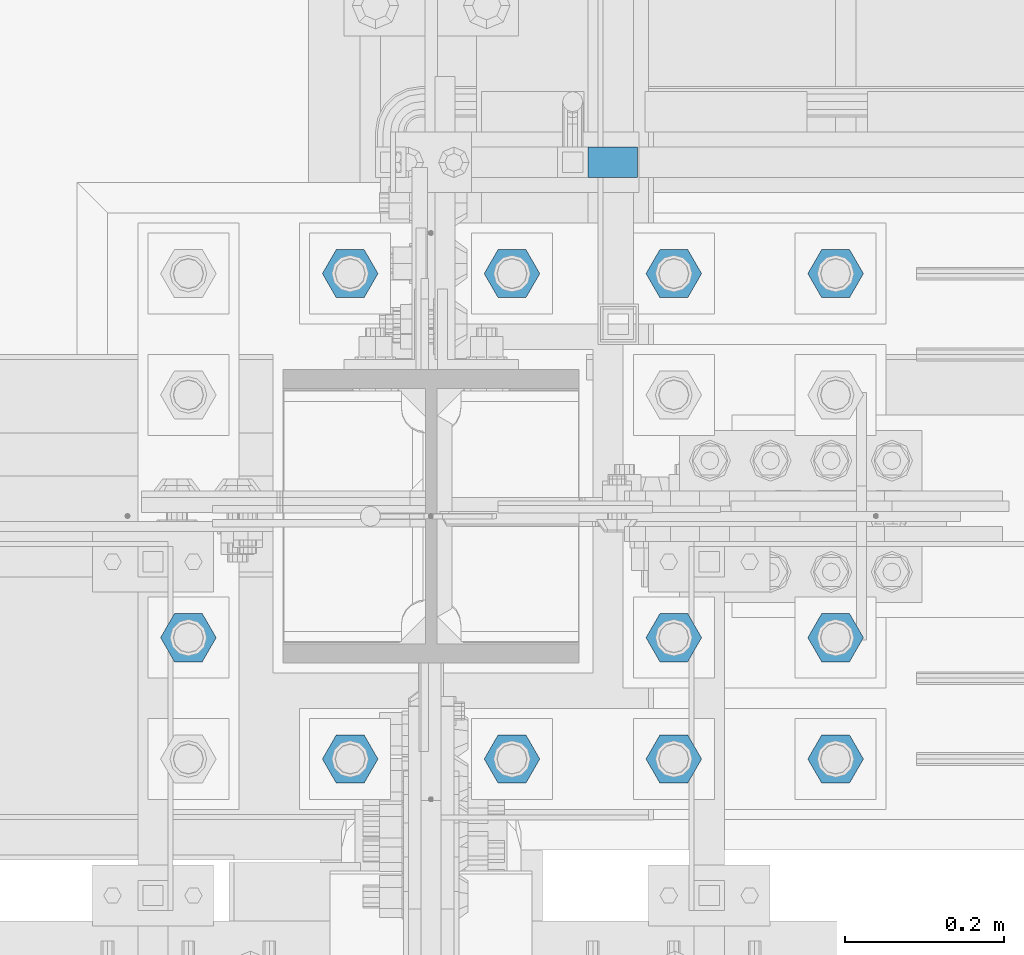
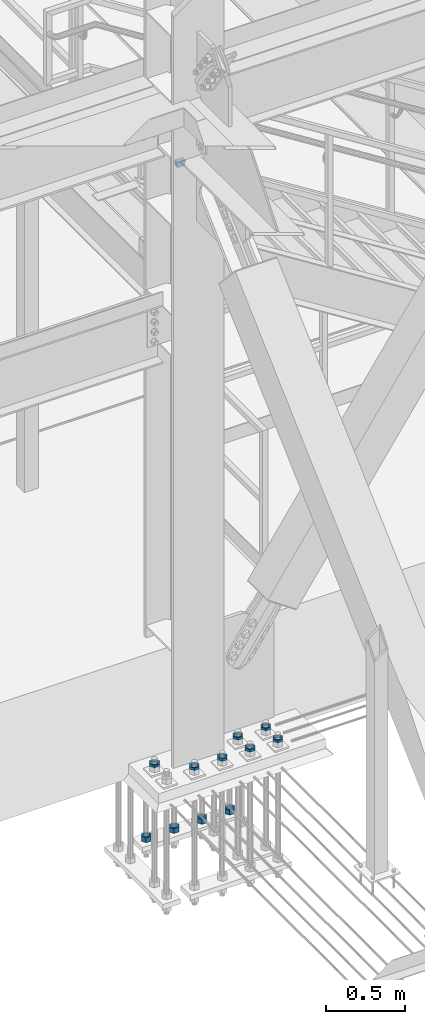
# One storey, part 2825 of 3843: 12 beams, 2 elements without a shape of their own.
"""IFC2X3 building model written with IfcOpenShell, lengths in millimetres."""

from ifc_helpers import new_model, si_unit, frame, origin_with_axes, place, context, subcontext, project, spatial, faceted_brep, material, type_object, element, aggregate, save


model = new_model("IFC2X3")

# Units and contexts
model_context = context("Model", 3, precision=1e-05, world=origin_with_axes())
body_context = subcontext(model_context, "Body", "Model", "MODEL_VIEW")
ifc_project = project(units=[si_unit("LENGTHUNIT", "METRE", prefix="MILLI"), si_unit("AREAUNIT", "SQUARE_METRE"), si_unit("VOLUMEUNIT", "CUBIC_METRE"), si_unit("MASSUNIT", "GRAM", prefix="KILO"), si_unit("TIMEUNIT", "SECOND"), si_unit("PLANEANGLEUNIT", "RADIAN"), si_unit("SOLIDANGLEUNIT", "STERADIAN"), si_unit("THERMODYNAMICTEMPERATUREUNIT", "DEGREE_CELSIUS"), si_unit("LUMINOUSINTENSITYUNIT", "LUMEN")], contexts=[model_context])

# Site, building, storey
site_placement = place(None, origin_with_axes())
site = spatial("IfcSite", under=ifc_project, at=site_placement, CompositionType="ELEMENT")
building_placement = place(site_placement, origin_with_axes())
building = spatial("IfcBuilding", under=site, at=building_placement, Name="Undefined", CompositionType="ELEMENT")
storey_placement = place(building_placement, origin_with_axes())
storey = spatial("IfcBuildingStorey", under=building, at=storey_placement, Name="Undefined", CompositionType="ELEMENT", Elevation=0.0)

# Assembly, beam
assembly_1_placement = place(storey_placement, origin_with_axes())
assembly_1 = element("IfcElementAssembly", 1, at=assembly_1_placement, inside=storey, Name="RAIL", AssemblyPlace="NOTDEFINED", PredefinedType="RIGID_FRAME")
ifc_material_1 = material()
beam_type_1 = type_object("IfcBeamType", Name="HSS1-1/2X1-1/2X1/4", PredefinedType="NOTDEFINED")
beam_1_placement = place(assembly_1_placement, frame((56184.7999995789, 26060.40000005, 33832.8000003305), z_axis=(0.0, 0.0, 1.0), x_axis=(-1.0, 0.0, 0.0)))
beam_1 = element("IfcBeam", 2, at=beam_1_placement, type_object=beam_type_1, material=ifc_material_1, Name="RAIL", ObjectType="HSS1-1/2X1-1/2X1/4", context=body_context, shape_type="Brep", body=[
    faceted_brep([(57.1499996326966, -19.0500003825, 19.0499992351833), (57.1499996707935, -19.0499992350015, -19.0499992348123), (57.1499996707935, 19.0499992350015, -19.0499992348123), (57.1499996326966, 19.0499992350015, 19.0499992351833), (57.1499996390485, -12.6999993300014, 12.699999330187), (57.1499996390485, 12.6999993300014, 12.699999330187), (57.1499996644488, 12.6999993300014, -12.6999993298159), (57.1499996644488, -12.6999993300014, -12.6999993298159), (-5.50550323203788, 19.0499992350015, 19.0499992349796), (-5.50550323203788, -19.0499992350015, 19.0499992349796), (5.50550336230663, -19.0499992350015, -19.0499992349796), (5.50550336230663, 19.0499992350015, -19.0499992349796), (-3.67033542007266, 12.6999993300014, 12.6999993299905), (-3.67033542007266, -12.6999993300014, 12.6999993299905), (3.67033555034141, -12.6999993300014, -12.6999993299905), (3.67033555034141, 12.6999993300014, -12.6999993299905)], [[[0, 1, 2, 3], [4, 5, 6, 7]], [[8, 9, 0, 3]], [[10, 11, 2, 1]], [[9, 10, 1, 0]], [[11, 8, 3, 2]], [[10, 9, 8, 11], [12, 13, 14, 15]], [[14, 13, 4, 7]], [[15, 14, 7, 6]], [[12, 15, 6, 5]], [[13, 12, 5, 4]]]),
])
aggregate(assembly_1, [beam_1])

# Assembly, beams
assembly_2_placement = place(storey_placement, origin_with_axes())
assembly_2 = element("IfcElementAssembly", 3, at=assembly_2_placement, inside=storey, Name="TEMPLATE", AssemblyPlace="NOTDEFINED", PredefinedType="RIGID_FRAME")
ifc_material_2 = material(Name="STEEL/A572-50")
beam_type_2 = type_object("IfcBeamType", Name="1-1/2_HEAVY_HEX_NUT", PredefinedType="NOTDEFINED")
beam_2_placement = place(assembly_2_placement, frame((55829.2, 25920.7, 28841.7000015259), z_axis=(0.0, -1.0, 0.0), x_axis=(0.0, 0.0, -1.0)))
beam_2 = element("IfcBeam", 4, at=beam_2_placement, type_object=beam_type_2, material=ifc_material_2, Name="NUT", ObjectType="1-1/2_HEAVY_HEX_NUT", context=body_context, shape_type="Brep", body=[
    faceted_brep([(0.0, -34.9199981689453, 0.0), (0.0, -17.4599990844727, -30.25), (38.0999999999985, -17.4599990844727, -30.25), (38.0999999999985, -34.9199981689453, 0.0), (0.0, 17.4599990844727, -30.25), (38.0999999999985, 17.4599990844727, -30.25), (0.0, 34.9199981689453, 0.0), (38.0999999999985, 34.9199981689453, 0.0), (0.0, 17.4599990844727, 30.25), (38.0999999999985, 17.4599990844727, 30.25), (0.0, -17.4599990844727, 30.25), (38.0999999999985, -17.4599990844727, 30.25), (0.0, 0.0, 20.6399993896484), (0.0, 8.9553601105581, 18.5959968835959), (38.0999999999985, 8.9553601105581, 18.5959968835959), (38.0999999999985, 0.0, 20.6399993896484), (0.0, 16.1370013209525, 12.8688291298167), (38.0999999999985, 16.1370013209525, 12.8688291298167), (0.0, 20.1225115123816, 4.59283194104501), (38.0999999999985, 20.1225115123816, 4.59283194104501), (0.0, 20.1225115123816, -4.59283194104501), (38.0999999999985, 20.1225115123816, -4.59283194104501), (0.0, 16.1370013209525, -12.8688291298167), (38.0999999999985, 16.1370013209525, -12.8688291298167), (0.0, 8.9553601105581, -18.5959968835959), (38.0999999999985, 8.9553601105581, -18.5959968835959), (0.0, 0.0, -20.6399993896484), (38.0999999999985, 0.0, -20.6399993896484), (0.0, -8.9553601105581, -18.5959968835959), (38.0999999999985, -8.9553601105581, -18.5959968835959), (0.0, -16.1370013209525, -12.8688291298167), (38.0999999999985, -16.1370013209525, -12.8688291298167), (0.0, -20.1225115123816, -4.59283194104501), (38.0999999999985, -20.1225115123816, -4.59283194104501), (0.0, -20.1225115123816, 4.59283194104501), (38.0999999999985, -20.1225115123816, 4.59283194104501), (0.0, -16.1370013209525, 12.8688291298167), (38.0999999999985, -16.1370013209525, 12.8688291298167), (0.0, -8.9553601105581, 18.5959968835959), (38.0999999999985, -8.9553601105581, 18.5959968835959)], [[[0, 1, 2, 3]], [[1, 4, 5, 2]], [[4, 6, 7, 5]], [[6, 8, 9, 7]], [[8, 10, 11, 9]], [[10, 0, 3, 11]], [[12, 13, 14, 15]], [[13, 16, 17, 14]], [[16, 18, 19, 17]], [[18, 20, 21, 19]], [[20, 22, 23, 21]], [[22, 24, 25, 23]], [[24, 26, 27, 25]], [[26, 28, 29, 27]], [[28, 30, 31, 29]], [[30, 32, 33, 31]], [[32, 34, 35, 33]], [[34, 36, 37, 35]], [[36, 38, 39, 37]], [[38, 12, 15, 39]], [[5, 7, 9, 11, 3, 2], [17, 19, 21, 23, 25, 27, 29, 31, 33, 35, 37, 39, 15, 14]], [[10, 8, 6, 4, 1, 0], [38, 36, 34, 32, 30, 28, 26, 24, 22, 20, 18, 16, 13, 12]]]),
])
beam_3_placement = place(assembly_2_placement, frame((56032.4, 25920.7, 28841.7000015259), z_axis=(0.0, -1.0, 0.0), x_axis=(0.0, 0.0, -1.0)))
beam_3 = element("IfcBeam", 5, at=beam_3_placement, type_object=beam_type_2, material=ifc_material_2, Name="NUT", ObjectType="1-1/2_HEAVY_HEX_NUT", context=body_context, shape_type="Brep", body=[
    faceted_brep([(0.0, -34.9199981689453, 0.0), (0.0, -17.4599990844727, -30.25), (38.0999999999985, -17.4599990844727, -30.25), (38.0999999999985, -34.9199981689453, 0.0), (0.0, 17.4599990844727, -30.25), (38.0999999999985, 17.4599990844727, -30.25), (0.0, 34.9199981689453, 0.0), (38.0999999999985, 34.9199981689453, 0.0), (0.0, 17.4599990844727, 30.25), (38.0999999999985, 17.4599990844727, 30.25), (0.0, -17.4599990844727, 30.25), (38.0999999999985, -17.4599990844727, 30.25), (0.0, 0.0, 20.6399993896484), (0.0, 8.9553601105581, 18.5959968835959), (38.0999999999985, 8.9553601105581, 18.5959968835959), (38.0999999999985, 0.0, 20.6399993896484), (0.0, 16.1370013209525, 12.8688291298167), (38.0999999999985, 16.1370013209525, 12.8688291298167), (0.0, 20.1225115123816, 4.59283194104501), (38.0999999999985, 20.1225115123816, 4.59283194104501), (0.0, 20.1225115123816, -4.59283194104501), (38.0999999999985, 20.1225115123816, -4.59283194104501), (0.0, 16.1370013209525, -12.8688291298167), (38.0999999999985, 16.1370013209525, -12.8688291298167), (0.0, 8.9553601105581, -18.5959968835959), (38.0999999999985, 8.9553601105581, -18.5959968835959), (0.0, 0.0, -20.6399993896484), (38.0999999999985, 0.0, -20.6399993896484), (0.0, -8.9553601105581, -18.5959968835959), (38.0999999999985, -8.9553601105581, -18.5959968835959), (0.0, -16.1370013209525, -12.8688291298167), (38.0999999999985, -16.1370013209525, -12.8688291298167), (0.0, -20.1225115123816, -4.59283194104501), (38.0999999999985, -20.1225115123816, -4.59283194104501), (0.0, -20.1225115123816, 4.59283194104501), (38.0999999999985, -20.1225115123816, 4.59283194104501), (0.0, -16.1370013209525, 12.8688291298167), (38.0999999999985, -16.1370013209525, 12.8688291298167), (0.0, -8.9553601105581, 18.5959968835959), (38.0999999999985, -8.9553601105581, 18.5959968835959)], [[[0, 1, 2, 3]], [[1, 4, 5, 2]], [[4, 6, 7, 5]], [[6, 8, 9, 7]], [[8, 10, 11, 9]], [[10, 0, 3, 11]], [[12, 13, 14, 15]], [[13, 16, 17, 14]], [[16, 18, 19, 17]], [[18, 20, 21, 19]], [[20, 22, 23, 21]], [[22, 24, 25, 23]], [[24, 26, 27, 25]], [[26, 28, 29, 27]], [[28, 30, 31, 29]], [[30, 32, 33, 31]], [[32, 34, 35, 33]], [[34, 36, 37, 35]], [[36, 38, 39, 37]], [[38, 12, 15, 39]], [[5, 7, 9, 11, 3, 2], [17, 19, 21, 23, 25, 27, 29, 31, 33, 35, 37, 39, 15, 14]], [[10, 8, 6, 4, 1, 0], [38, 36, 34, 32, 30, 28, 26, 24, 22, 20, 18, 16, 13, 12]]]),
])
beam_4_placement = place(assembly_2_placement, frame((56235.6, 25920.7, 28841.7000015259), z_axis=(0.0, 1.0, 0.0), x_axis=(0.0, 0.0, -1.0)))
beam_4 = element("IfcBeam", 6, at=beam_4_placement, type_object=beam_type_2, material=ifc_material_2, Name="NUT", ObjectType="1-1/2_HEAVY_HEX_NUT", context=body_context, shape_type="Brep", body=[
    faceted_brep([(0.0, -34.9199981689453, 0.0), (0.0, -17.4599990844727, -30.25), (38.0999999999985, -17.4599990844727, -30.25), (38.0999999999985, -34.9199981689453, 0.0), (0.0, 17.4599990844727, -30.25), (38.0999999999985, 17.4599990844727, -30.25), (0.0, 34.9199981689453, 0.0), (38.0999999999985, 34.9199981689453, 0.0), (0.0, 17.4599990844727, 30.25), (38.0999999999985, 17.4599990844727, 30.25), (0.0, -17.4599990844727, 30.25), (38.0999999999985, -17.4599990844727, 30.25), (0.0, 0.0, 20.6399993896484), (0.0, 8.9553601105581, 18.5959968835959), (38.0999999999985, 8.9553601105581, 18.5959968835959), (38.0999999999985, 0.0, 20.6399993896484), (0.0, 16.1370013209525, 12.8688291298167), (38.0999999999985, 16.1370013209525, 12.8688291298167), (0.0, 20.1225115123816, 4.59283194104501), (38.0999999999985, 20.1225115123816, 4.59283194104501), (0.0, 20.1225115123816, -4.59283194104501), (38.0999999999985, 20.1225115123816, -4.59283194104501), (0.0, 16.1370013209525, -12.8688291298167), (38.0999999999985, 16.1370013209525, -12.8688291298167), (0.0, 8.9553601105581, -18.5959968835959), (38.0999999999985, 8.9553601105581, -18.5959968835959), (0.0, 0.0, -20.6399993896484), (38.0999999999985, 0.0, -20.6399993896484), (0.0, -8.9553601105581, -18.5959968835959), (38.0999999999985, -8.9553601105581, -18.5959968835959), (0.0, -16.1370013209525, -12.8688291298167), (38.0999999999985, -16.1370013209525, -12.8688291298167), (0.0, -20.1225115123816, -4.59283194104501), (38.0999999999985, -20.1225115123816, -4.59283194104501), (0.0, -20.1225115123816, 4.59283194104501), (38.0999999999985, -20.1225115123816, 4.59283194104501), (0.0, -16.1370013209525, 12.8688291298167), (38.0999999999985, -16.1370013209525, 12.8688291298167), (0.0, -8.9553601105581, 18.5959968835959), (38.0999999999985, -8.9553601105581, 18.5959968835959)], [[[0, 1, 2, 3]], [[1, 4, 5, 2]], [[4, 6, 7, 5]], [[6, 8, 9, 7]], [[8, 10, 11, 9]], [[10, 0, 3, 11]], [[12, 13, 14, 15]], [[13, 16, 17, 14]], [[16, 18, 19, 17]], [[18, 20, 21, 19]], [[20, 22, 23, 21]], [[22, 24, 25, 23]], [[24, 26, 27, 25]], [[26, 28, 29, 27]], [[28, 30, 31, 29]], [[30, 32, 33, 31]], [[32, 34, 35, 33]], [[34, 36, 37, 35]], [[36, 38, 39, 37]], [[38, 12, 15, 39]], [[5, 7, 9, 11, 3, 2], [17, 19, 21, 23, 25, 27, 29, 31, 33, 35, 37, 39, 15, 14]], [[10, 8, 6, 4, 1, 0], [38, 36, 34, 32, 30, 28, 26, 24, 22, 20, 18, 16, 13, 12]]]),
])
beam_5_placement = place(assembly_2_placement, frame((56438.8, 25920.7, 28841.7000015259), z_axis=(0.0, 1.0, 0.0), x_axis=(0.0, 0.0, -1.0)))
beam_5 = element("IfcBeam", 7, at=beam_5_placement, type_object=beam_type_2, material=ifc_material_2, Name="NUT", ObjectType="1-1/2_HEAVY_HEX_NUT", context=body_context, shape_type="Brep", body=[
    faceted_brep([(0.0, -34.9199981689453, 0.0), (0.0, -17.4599990844727, -30.25), (38.0999999999985, -17.4599990844727, -30.25), (38.0999999999985, -34.9199981689453, 0.0), (0.0, 17.4599990844727, -30.25), (38.0999999999985, 17.4599990844727, -30.25), (0.0, 34.9199981689453, 0.0), (38.0999999999985, 34.9199981689453, 0.0), (0.0, 17.4599990844727, 30.25), (38.0999999999985, 17.4599990844727, 30.25), (0.0, -17.4599990844727, 30.25), (38.0999999999985, -17.4599990844727, 30.25), (0.0, 0.0, 20.6399993896484), (0.0, 8.9553601105581, 18.5959968835959), (38.0999999999985, 8.9553601105581, 18.5959968835959), (38.0999999999985, 0.0, 20.6399993896484), (0.0, 16.1370013209525, 12.8688291298167), (38.0999999999985, 16.1370013209525, 12.8688291298167), (0.0, 20.1225115123816, 4.59283194104501), (38.0999999999985, 20.1225115123816, 4.59283194104501), (0.0, 20.1225115123816, -4.59283194104501), (38.0999999999985, 20.1225115123816, -4.59283194104501), (0.0, 16.1370013209525, -12.8688291298167), (38.0999999999985, 16.1370013209525, -12.8688291298167), (0.0, 8.9553601105581, -18.5959968835959), (38.0999999999985, 8.9553601105581, -18.5959968835959), (0.0, 0.0, -20.6399993896484), (38.0999999999985, 0.0, -20.6399993896484), (0.0, -8.9553601105581, -18.5959968835959), (38.0999999999985, -8.9553601105581, -18.5959968835959), (0.0, -16.1370013209525, -12.8688291298167), (38.0999999999985, -16.1370013209525, -12.8688291298167), (0.0, -20.1225115123816, -4.59283194104501), (38.0999999999985, -20.1225115123816, -4.59283194104501), (0.0, -20.1225115123816, 4.59283194104501), (38.0999999999985, -20.1225115123816, 4.59283194104501), (0.0, -16.1370013209525, 12.8688291298167), (38.0999999999985, -16.1370013209525, 12.8688291298167), (0.0, -8.9553601105581, 18.5959968835959), (38.0999999999985, -8.9553601105581, 18.5959968835959)], [[[0, 1, 2, 3]], [[1, 4, 5, 2]], [[4, 6, 7, 5]], [[6, 8, 9, 7]], [[8, 10, 11, 9]], [[10, 0, 3, 11]], [[12, 13, 14, 15]], [[13, 16, 17, 14]], [[16, 18, 19, 17]], [[18, 20, 21, 19]], [[20, 22, 23, 21]], [[22, 24, 25, 23]], [[24, 26, 27, 25]], [[26, 28, 29, 27]], [[28, 30, 31, 29]], [[30, 32, 33, 31]], [[32, 34, 35, 33]], [[34, 36, 37, 35]], [[36, 38, 39, 37]], [[38, 12, 15, 39]], [[5, 7, 9, 11, 3, 2], [17, 19, 21, 23, 25, 27, 29, 31, 33, 35, 37, 39, 15, 14]], [[10, 8, 6, 4, 1, 0], [38, 36, 34, 32, 30, 28, 26, 24, 22, 20, 18, 16, 13, 12]]]),
])
beam_type_3 = type_object("IfcBeamType", Name="1-1/2_HALF_NUT", PredefinedType="NOTDEFINED")
beam_6_placement = place(assembly_2_placement, frame((55829.2, 25311.1, 29749.75), z_axis=(0.0, -1.0, 0.0), x_axis=(0.0, 0.0, -1.0)))
beam_6 = element("IfcBeam", 8, at=beam_6_placement, type_object=beam_type_3, material=ifc_material_2, Name="NUT", ObjectType="1-1/2_HALF_NUT", context=body_context, shape_type="Brep", body=[
    faceted_brep([(0.0, -34.9199981689453, 0.0), (0.0, -17.4599990844727, -30.25), (19.0500000000029, -17.4599990844727, -30.25), (19.0500000000029, -34.9199981689453, 0.0), (0.0, 17.4599990844727, -30.25), (19.0500000000029, 17.4599990844727, -30.25), (0.0, 34.9199981689453, 0.0), (19.0500000000029, 34.9199981689453, 0.0), (0.0, 17.4599990844727, 30.25), (19.0500000000029, 17.4599990844727, 30.25), (0.0, -17.4599990844727, 30.25), (19.0500000000029, -17.4599990844727, 30.25), (0.0, 0.0, 20.6399993896484), (0.0, 8.9553601105581, 18.5959968835959), (19.0500000000029, 8.95536011056538, 18.5959968835959), (19.0500000000029, 0.0, 20.6399993896484), (0.0, 16.1370013209525, 12.8688291298167), (19.0500000000029, 16.1370013209489, 12.8688291298167), (0.0, 20.1225115123816, 4.59283194104501), (19.0500000000029, 20.1225115123852, 4.59283194104501), (0.0, 20.1225115123816, -4.59283194104501), (19.0500000000029, 20.1225115123852, -4.59283194104501), (0.0, 16.1370013209525, -12.8688291298167), (19.0500000000029, 16.1370013209489, -12.8688291298167), (0.0, 8.9553601105581, -18.5959968835959), (19.0500000000029, 8.95536011056538, -18.5959968835959), (0.0, 0.0, -20.6399993896484), (19.0500000000029, 0.0, -20.6399993896484), (0.0, -8.9553601105581, -18.5959968835959), (19.0500000000029, -8.95536011056538, -18.5959968835959), (0.0, -16.1370013209525, -12.8688291298167), (19.0500000000029, -16.1370013209489, -12.8688291298167), (0.0, -20.1225115123816, -4.59283194104501), (19.0500000000029, -20.1225115123852, -4.59283194104501), (0.0, -20.1225115123816, 4.59283194104501), (19.0500000000029, -20.1225115123852, 4.59283194104501), (0.0, -16.1370013209525, 12.8688291298167), (19.0500000000029, -16.1370013209489, 12.8688291298167), (0.0, -8.9553601105581, 18.5959968835959), (19.0500000000029, -8.95536011056538, 18.5959968835959)], [[[0, 1, 2, 3]], [[1, 4, 5, 2]], [[4, 6, 7, 5]], [[6, 8, 9, 7]], [[8, 10, 11, 9]], [[10, 0, 3, 11]], [[12, 13, 14, 15]], [[13, 16, 17, 14]], [[16, 18, 19, 17]], [[18, 20, 21, 19]], [[20, 22, 23, 21]], [[22, 24, 25, 23]], [[24, 26, 27, 25]], [[26, 28, 29, 27]], [[28, 30, 31, 29]], [[30, 32, 33, 31]], [[32, 34, 35, 33]], [[34, 36, 37, 35]], [[36, 38, 39, 37]], [[38, 12, 15, 39]], [[5, 7, 9, 11, 3, 2], [17, 19, 21, 23, 25, 27, 29, 31, 33, 35, 37, 39, 15, 14]], [[10, 8, 6, 4, 1, 0], [38, 36, 34, 32, 30, 28, 26, 24, 22, 20, 18, 16, 13, 12]]]),
])
beam_7_placement = place(assembly_2_placement, frame((56032.4, 25311.1, 29749.75), z_axis=(0.0, -1.0, 0.0), x_axis=(0.0, 0.0, -1.0)))
beam_7 = element("IfcBeam", 9, at=beam_7_placement, type_object=beam_type_3, material=ifc_material_2, Name="NUT", ObjectType="1-1/2_HALF_NUT", context=body_context, shape_type="Brep", body=[
    faceted_brep([(0.0, -34.9199981689453, 0.0), (0.0, -17.4599990844727, -30.25), (19.0500000000029, -17.4599990844727, -30.25), (19.0500000000029, -34.9199981689453, 0.0), (0.0, 17.4599990844727, -30.25), (19.0500000000029, 17.4599990844727, -30.25), (0.0, 34.9199981689453, 0.0), (19.0500000000029, 34.9199981689453, 0.0), (0.0, 17.4599990844727, 30.25), (19.0500000000029, 17.4599990844727, 30.25), (0.0, -17.4599990844727, 30.25), (19.0500000000029, -17.4599990844727, 30.25), (0.0, 0.0, 20.6399993896484), (0.0, 8.9553601105581, 18.5959968835959), (19.0500000000029, 8.95536011056538, 18.5959968835959), (19.0500000000029, 0.0, 20.6399993896484), (0.0, 16.1370013209525, 12.8688291298167), (19.0500000000029, 16.1370013209489, 12.8688291298167), (0.0, 20.1225115123816, 4.59283194104501), (19.0500000000029, 20.1225115123852, 4.59283194104501), (0.0, 20.1225115123816, -4.59283194104501), (19.0500000000029, 20.1225115123852, -4.59283194104501), (0.0, 16.1370013209525, -12.8688291298167), (19.0500000000029, 16.1370013209489, -12.8688291298167), (0.0, 8.9553601105581, -18.5959968835959), (19.0500000000029, 8.95536011056538, -18.5959968835959), (0.0, 0.0, -20.6399993896484), (19.0500000000029, 0.0, -20.6399993896484), (0.0, -8.9553601105581, -18.5959968835959), (19.0500000000029, -8.95536011056538, -18.5959968835959), (0.0, -16.1370013209525, -12.8688291298167), (19.0500000000029, -16.1370013209489, -12.8688291298167), (0.0, -20.1225115123816, -4.59283194104501), (19.0500000000029, -20.1225115123852, -4.59283194104501), (0.0, -20.1225115123816, 4.59283194104501), (19.0500000000029, -20.1225115123852, 4.59283194104501), (0.0, -16.1370013209525, 12.8688291298167), (19.0500000000029, -16.1370013209489, 12.8688291298167), (0.0, -8.9553601105581, 18.5959968835959), (19.0500000000029, -8.95536011056538, 18.5959968835959)], [[[0, 1, 2, 3]], [[1, 4, 5, 2]], [[4, 6, 7, 5]], [[6, 8, 9, 7]], [[8, 10, 11, 9]], [[10, 0, 3, 11]], [[12, 13, 14, 15]], [[13, 16, 17, 14]], [[16, 18, 19, 17]], [[18, 20, 21, 19]], [[20, 22, 23, 21]], [[22, 24, 25, 23]], [[24, 26, 27, 25]], [[26, 28, 29, 27]], [[28, 30, 31, 29]], [[30, 32, 33, 31]], [[32, 34, 35, 33]], [[34, 36, 37, 35]], [[36, 38, 39, 37]], [[38, 12, 15, 39]], [[5, 7, 9, 11, 3, 2], [17, 19, 21, 23, 25, 27, 29, 31, 33, 35, 37, 39, 15, 14]], [[10, 8, 6, 4, 1, 0], [38, 36, 34, 32, 30, 28, 26, 24, 22, 20, 18, 16, 13, 12]]]),
])
beam_8_placement = place(assembly_2_placement, frame((56235.6, 25311.1, 29749.75), z_axis=(0.0, 1.0, 0.0), x_axis=(0.0, 0.0, -1.0)))
beam_8 = element("IfcBeam", 10, at=beam_8_placement, type_object=beam_type_3, material=ifc_material_2, Name="NUT", ObjectType="1-1/2_HALF_NUT", context=body_context, shape_type="Brep", body=[
    faceted_brep([(0.0, -34.9199981689453, 0.0), (0.0, -17.4599990844727, -30.25), (19.0500000000029, -17.4599990844727, -30.25), (19.0500000000029, -34.9199981689453, 0.0), (0.0, 17.4599990844727, -30.25), (19.0500000000029, 17.4599990844727, -30.25), (0.0, 34.9199981689453, 0.0), (19.0500000000029, 34.9199981689453, 0.0), (0.0, 17.4599990844727, 30.25), (19.0500000000029, 17.4599990844727, 30.25), (0.0, -17.4599990844727, 30.25), (19.0500000000029, -17.4599990844727, 30.25), (0.0, 0.0, 20.6399993896484), (0.0, 8.9553601105581, 18.5959968835959), (19.0500000000029, 8.95536011056538, 18.5959968835959), (19.0500000000029, 0.0, 20.6399993896484), (0.0, 16.1370013209525, 12.8688291298167), (19.0500000000029, 16.1370013209489, 12.8688291298167), (0.0, 20.1225115123816, 4.59283194104501), (19.0500000000029, 20.1225115123852, 4.59283194104501), (0.0, 20.1225115123816, -4.59283194104501), (19.0500000000029, 20.1225115123852, -4.59283194104501), (0.0, 16.1370013209525, -12.8688291298167), (19.0500000000029, 16.1370013209489, -12.8688291298167), (0.0, 8.9553601105581, -18.5959968835959), (19.0500000000029, 8.95536011056538, -18.5959968835959), (0.0, 0.0, -20.6399993896484), (19.0500000000029, 0.0, -20.6399993896484), (0.0, -8.9553601105581, -18.5959968835959), (19.0500000000029, -8.95536011056538, -18.5959968835959), (0.0, -16.1370013209525, -12.8688291298167), (19.0500000000029, -16.1370013209489, -12.8688291298167), (0.0, -20.1225115123816, -4.59283194104501), (19.0500000000029, -20.1225115123852, -4.59283194104501), (0.0, -20.1225115123816, 4.59283194104501), (19.0500000000029, -20.1225115123852, 4.59283194104501), (0.0, -16.1370013209525, 12.8688291298167), (19.0500000000029, -16.1370013209489, 12.8688291298167), (0.0, -8.9553601105581, 18.5959968835959), (19.0500000000029, -8.95536011056538, 18.5959968835959)], [[[0, 1, 2, 3]], [[1, 4, 5, 2]], [[4, 6, 7, 5]], [[6, 8, 9, 7]], [[8, 10, 11, 9]], [[10, 0, 3, 11]], [[12, 13, 14, 15]], [[13, 16, 17, 14]], [[16, 18, 19, 17]], [[18, 20, 21, 19]], [[20, 22, 23, 21]], [[22, 24, 25, 23]], [[24, 26, 27, 25]], [[26, 28, 29, 27]], [[28, 30, 31, 29]], [[30, 32, 33, 31]], [[32, 34, 35, 33]], [[34, 36, 37, 35]], [[36, 38, 39, 37]], [[38, 12, 15, 39]], [[5, 7, 9, 11, 3, 2], [17, 19, 21, 23, 25, 27, 29, 31, 33, 35, 37, 39, 15, 14]], [[10, 8, 6, 4, 1, 0], [38, 36, 34, 32, 30, 28, 26, 24, 22, 20, 18, 16, 13, 12]]]),
])
beam_9_placement = place(assembly_2_placement, frame((56438.8, 25311.1, 29749.75), z_axis=(0.0, 1.0, 0.0), x_axis=(0.0, 0.0, -1.0)))
beam_9 = element("IfcBeam", 11, at=beam_9_placement, type_object=beam_type_3, material=ifc_material_2, Name="NUT", ObjectType="1-1/2_HALF_NUT", context=body_context, shape_type="Brep", body=[
    faceted_brep([(0.0, -34.9199981689453, 0.0), (0.0, -17.4599990844727, -30.25), (19.0500000000029, -17.4599990844727, -30.25), (19.0500000000029, -34.9199981689453, 0.0), (0.0, 17.4599990844727, -30.25), (19.0500000000029, 17.4599990844727, -30.25), (0.0, 34.9199981689453, 0.0), (19.0500000000029, 34.9199981689453, 0.0), (0.0, 17.4599990844727, 30.25), (19.0500000000029, 17.4599990844727, 30.25), (0.0, -17.4599990844727, 30.25), (19.0500000000029, -17.4599990844727, 30.25), (0.0, 0.0, 20.6399993896484), (0.0, 8.9553601105581, 18.5959968835959), (19.0500000000029, 8.95536011056538, 18.5959968835959), (19.0500000000029, 0.0, 20.6399993896484), (0.0, 16.1370013209525, 12.8688291298167), (19.0500000000029, 16.1370013209489, 12.8688291298167), (0.0, 20.1225115123816, 4.59283194104501), (19.0500000000029, 20.1225115123852, 4.59283194104501), (0.0, 20.1225115123816, -4.59283194104501), (19.0500000000029, 20.1225115123852, -4.59283194104501), (0.0, 16.1370013209525, -12.8688291298167), (19.0500000000029, 16.1370013209489, -12.8688291298167), (0.0, 8.9553601105581, -18.5959968835959), (19.0500000000029, 8.95536011056538, -18.5959968835959), (0.0, 0.0, -20.6399993896484), (19.0500000000029, 0.0, -20.6399993896484), (0.0, -8.9553601105581, -18.5959968835959), (19.0500000000029, -8.95536011056538, -18.5959968835959), (0.0, -16.1370013209525, -12.8688291298167), (19.0500000000029, -16.1370013209489, -12.8688291298167), (0.0, -20.1225115123816, -4.59283194104501), (19.0500000000029, -20.1225115123852, -4.59283194104501), (0.0, -20.1225115123816, 4.59283194104501), (19.0500000000029, -20.1225115123852, 4.59283194104501), (0.0, -16.1370013209525, 12.8688291298167), (19.0500000000029, -16.1370013209489, 12.8688291298167), (0.0, -8.9553601105581, 18.5959968835959), (19.0500000000029, -8.95536011056538, 18.5959968835959)], [[[0, 1, 2, 3]], [[1, 4, 5, 2]], [[4, 6, 7, 5]], [[6, 8, 9, 7]], [[8, 10, 11, 9]], [[10, 0, 3, 11]], [[12, 13, 14, 15]], [[13, 16, 17, 14]], [[16, 18, 19, 17]], [[18, 20, 21, 19]], [[20, 22, 23, 21]], [[22, 24, 25, 23]], [[24, 26, 27, 25]], [[26, 28, 29, 27]], [[28, 30, 31, 29]], [[30, 32, 33, 31]], [[32, 34, 35, 33]], [[34, 36, 37, 35]], [[36, 38, 39, 37]], [[38, 12, 15, 39]], [[5, 7, 9, 11, 3, 2], [17, 19, 21, 23, 25, 27, 29, 31, 33, 35, 37, 39, 15, 14]], [[10, 8, 6, 4, 1, 0], [38, 36, 34, 32, 30, 28, 26, 24, 22, 20, 18, 16, 13, 12]]]),
])
beam_10_placement = place(assembly_2_placement, frame((55626.0, 25463.5, 29749.75), z_axis=(0.0, -1.0, 0.0), x_axis=(0.0, 0.0, -1.0)))
beam_10 = element("IfcBeam", 12, at=beam_10_placement, type_object=beam_type_3, material=ifc_material_2, Name="NUT", ObjectType="1-1/2_HALF_NUT", context=body_context, shape_type="Brep", body=[
    faceted_brep([(0.0, -34.9199981689453, 0.0), (0.0, -17.4599990844727, -30.25), (19.0500000000029, -17.4599990844727, -30.25), (19.0500000000029, -34.9199981689453, 0.0), (0.0, 17.4599990844727, -30.25), (19.0500000000029, 17.4599990844727, -30.25), (0.0, 34.9199981689453, 0.0), (19.0500000000029, 34.9199981689453, 0.0), (0.0, 17.4599990844727, 30.25), (19.0500000000029, 17.4599990844727, 30.25), (0.0, -17.4599990844727, 30.25), (19.0500000000029, -17.4599990844727, 30.25), (0.0, 0.0, 20.6399993896484), (0.0, 8.9553601105581, 18.5959968835959), (19.0500000000029, 8.95536011056538, 18.5959968835959), (19.0500000000029, 0.0, 20.6399993896484), (0.0, 16.1370013209525, 12.8688291298167), (19.0500000000029, 16.1370013209489, 12.8688291298167), (0.0, 20.1225115123816, 4.59283194104501), (19.0500000000029, 20.1225115123852, 4.59283194104501), (0.0, 20.1225115123816, -4.59283194104501), (19.0500000000029, 20.1225115123852, -4.59283194104501), (0.0, 16.1370013209525, -12.8688291298167), (19.0500000000029, 16.1370013209489, -12.8688291298167), (0.0, 8.9553601105581, -18.5959968835959), (19.0500000000029, 8.95536011056538, -18.5959968835959), (0.0, 0.0, -20.6399993896484), (19.0500000000029, 0.0, -20.6399993896484), (0.0, -8.9553601105581, -18.5959968835959), (19.0500000000029, -8.95536011056538, -18.5959968835959), (0.0, -16.1370013209525, -12.8688291298167), (19.0500000000029, -16.1370013209489, -12.8688291298167), (0.0, -20.1225115123816, -4.59283194104501), (19.0500000000029, -20.1225115123852, -4.59283194104501), (0.0, -20.1225115123816, 4.59283194104501), (19.0500000000029, -20.1225115123852, 4.59283194104501), (0.0, -16.1370013209525, 12.8688291298167), (19.0500000000029, -16.1370013209489, 12.8688291298167), (0.0, -8.9553601105581, 18.5959968835959), (19.0500000000029, -8.95536011056538, 18.5959968835959)], [[[0, 1, 2, 3]], [[1, 4, 5, 2]], [[4, 6, 7, 5]], [[6, 8, 9, 7]], [[8, 10, 11, 9]], [[10, 0, 3, 11]], [[12, 13, 14, 15]], [[13, 16, 17, 14]], [[16, 18, 19, 17]], [[18, 20, 21, 19]], [[20, 22, 23, 21]], [[22, 24, 25, 23]], [[24, 26, 27, 25]], [[26, 28, 29, 27]], [[28, 30, 31, 29]], [[30, 32, 33, 31]], [[32, 34, 35, 33]], [[34, 36, 37, 35]], [[36, 38, 39, 37]], [[38, 12, 15, 39]], [[5, 7, 9, 11, 3, 2], [17, 19, 21, 23, 25, 27, 29, 31, 33, 35, 37, 39, 15, 14]], [[10, 8, 6, 4, 1, 0], [38, 36, 34, 32, 30, 28, 26, 24, 22, 20, 18, 16, 13, 12]]]),
])
beam_11_placement = place(assembly_2_placement, frame((56235.6, 25463.5, 29749.75), z_axis=(0.0, 1.0, 0.0), x_axis=(0.0, 0.0, -1.0)))
beam_11 = element("IfcBeam", 13, at=beam_11_placement, type_object=beam_type_3, material=ifc_material_2, Name="NUT", ObjectType="1-1/2_HALF_NUT", context=body_context, shape_type="Brep", body=[
    faceted_brep([(0.0, -34.9199981689453, 0.0), (0.0, -17.4599990844727, -30.25), (19.0500000000029, -17.4599990844727, -30.25), (19.0500000000029, -34.9199981689453, 0.0), (0.0, 17.4599990844727, -30.25), (19.0500000000029, 17.4599990844727, -30.25), (0.0, 34.9199981689453, 0.0), (19.0500000000029, 34.9199981689453, 0.0), (0.0, 17.4599990844727, 30.25), (19.0500000000029, 17.4599990844727, 30.25), (0.0, -17.4599990844727, 30.25), (19.0500000000029, -17.4599990844727, 30.25), (0.0, 0.0, 20.6399993896484), (0.0, 8.9553601105581, 18.5959968835959), (19.0500000000029, 8.95536011056538, 18.5959968835959), (19.0500000000029, 0.0, 20.6399993896484), (0.0, 16.1370013209525, 12.8688291298167), (19.0500000000029, 16.1370013209489, 12.8688291298167), (0.0, 20.1225115123816, 4.59283194104501), (19.0500000000029, 20.1225115123852, 4.59283194104501), (0.0, 20.1225115123816, -4.59283194104501), (19.0500000000029, 20.1225115123852, -4.59283194104501), (0.0, 16.1370013209525, -12.8688291298167), (19.0500000000029, 16.1370013209489, -12.8688291298167), (0.0, 8.9553601105581, -18.5959968835959), (19.0500000000029, 8.95536011056538, -18.5959968835959), (0.0, 0.0, -20.6399993896484), (19.0500000000029, 0.0, -20.6399993896484), (0.0, -8.9553601105581, -18.5959968835959), (19.0500000000029, -8.95536011056538, -18.5959968835959), (0.0, -16.1370013209525, -12.8688291298167), (19.0500000000029, -16.1370013209489, -12.8688291298167), (0.0, -20.1225115123816, -4.59283194104501), (19.0500000000029, -20.1225115123852, -4.59283194104501), (0.0, -20.1225115123816, 4.59283194104501), (19.0500000000029, -20.1225115123852, 4.59283194104501), (0.0, -16.1370013209525, 12.8688291298167), (19.0500000000029, -16.1370013209489, 12.8688291298167), (0.0, -8.9553601105581, 18.5959968835959), (19.0500000000029, -8.95536011056538, 18.5959968835959)], [[[0, 1, 2, 3]], [[1, 4, 5, 2]], [[4, 6, 7, 5]], [[6, 8, 9, 7]], [[8, 10, 11, 9]], [[10, 0, 3, 11]], [[12, 13, 14, 15]], [[13, 16, 17, 14]], [[16, 18, 19, 17]], [[18, 20, 21, 19]], [[20, 22, 23, 21]], [[22, 24, 25, 23]], [[24, 26, 27, 25]], [[26, 28, 29, 27]], [[28, 30, 31, 29]], [[30, 32, 33, 31]], [[32, 34, 35, 33]], [[34, 36, 37, 35]], [[36, 38, 39, 37]], [[38, 12, 15, 39]], [[5, 7, 9, 11, 3, 2], [17, 19, 21, 23, 25, 27, 29, 31, 33, 35, 37, 39, 15, 14]], [[10, 8, 6, 4, 1, 0], [38, 36, 34, 32, 30, 28, 26, 24, 22, 20, 18, 16, 13, 12]]]),
])
beam_12_placement = place(assembly_2_placement, frame((56438.8, 25463.5, 29749.75), z_axis=(0.0, 1.0, 0.0), x_axis=(0.0, 0.0, -1.0)))
beam_12 = element("IfcBeam", 14, at=beam_12_placement, type_object=beam_type_3, material=ifc_material_2, Name="NUT", ObjectType="1-1/2_HALF_NUT", context=body_context, shape_type="Brep", body=[
    faceted_brep([(0.0, -34.9199981689453, 0.0), (0.0, -17.4599990844727, -30.25), (19.0500000000029, -17.4599990844727, -30.25), (19.0500000000029, -34.9199981689453, 0.0), (0.0, 17.4599990844727, -30.25), (19.0500000000029, 17.4599990844727, -30.25), (0.0, 34.9199981689453, 0.0), (19.0500000000029, 34.9199981689453, 0.0), (0.0, 17.4599990844727, 30.25), (19.0500000000029, 17.4599990844727, 30.25), (0.0, -17.4599990844727, 30.25), (19.0500000000029, -17.4599990844727, 30.25), (0.0, 0.0, 20.6399993896484), (0.0, 8.9553601105581, 18.5959968835959), (19.0500000000029, 8.95536011056538, 18.5959968835959), (19.0500000000029, 0.0, 20.6399993896484), (0.0, 16.1370013209525, 12.8688291298167), (19.0500000000029, 16.1370013209489, 12.8688291298167), (0.0, 20.1225115123816, 4.59283194104501), (19.0500000000029, 20.1225115123852, 4.59283194104501), (0.0, 20.1225115123816, -4.59283194104501), (19.0500000000029, 20.1225115123852, -4.59283194104501), (0.0, 16.1370013209525, -12.8688291298167), (19.0500000000029, 16.1370013209489, -12.8688291298167), (0.0, 8.9553601105581, -18.5959968835959), (19.0500000000029, 8.95536011056538, -18.5959968835959), (0.0, 0.0, -20.6399993896484), (19.0500000000029, 0.0, -20.6399993896484), (0.0, -8.9553601105581, -18.5959968835959), (19.0500000000029, -8.95536011056538, -18.5959968835959), (0.0, -16.1370013209525, -12.8688291298167), (19.0500000000029, -16.1370013209489, -12.8688291298167), (0.0, -20.1225115123816, -4.59283194104501), (19.0500000000029, -20.1225115123852, -4.59283194104501), (0.0, -20.1225115123816, 4.59283194104501), (19.0500000000029, -20.1225115123852, 4.59283194104501), (0.0, -16.1370013209525, 12.8688291298167), (19.0500000000029, -16.1370013209489, 12.8688291298167), (0.0, -8.9553601105581, 18.5959968835959), (19.0500000000029, -8.95536011056538, 18.5959968835959)], [[[0, 1, 2, 3]], [[1, 4, 5, 2]], [[4, 6, 7, 5]], [[6, 8, 9, 7]], [[8, 10, 11, 9]], [[10, 0, 3, 11]], [[12, 13, 14, 15]], [[13, 16, 17, 14]], [[16, 18, 19, 17]], [[18, 20, 21, 19]], [[20, 22, 23, 21]], [[22, 24, 25, 23]], [[24, 26, 27, 25]], [[26, 28, 29, 27]], [[28, 30, 31, 29]], [[30, 32, 33, 31]], [[32, 34, 35, 33]], [[34, 36, 37, 35]], [[36, 38, 39, 37]], [[38, 12, 15, 39]], [[5, 7, 9, 11, 3, 2], [17, 19, 21, 23, 25, 27, 29, 31, 33, 35, 37, 39, 15, 14]], [[10, 8, 6, 4, 1, 0], [38, 36, 34, 32, 30, 28, 26, 24, 22, 20, 18, 16, 13, 12]]]),
])
aggregate(assembly_2, [beam_2, beam_3, beam_4, beam_5, beam_6, beam_7, beam_8, beam_9, beam_10, beam_11, beam_12])

save(model, "model.ifc")
